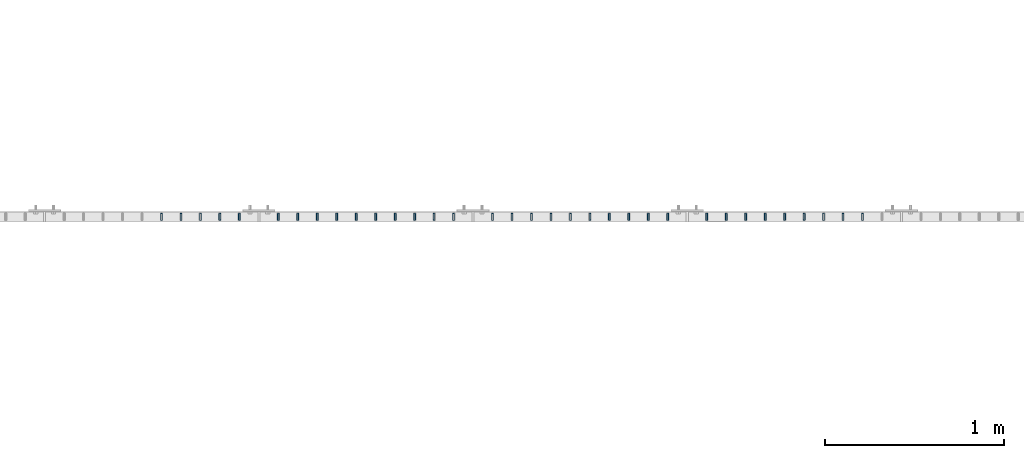
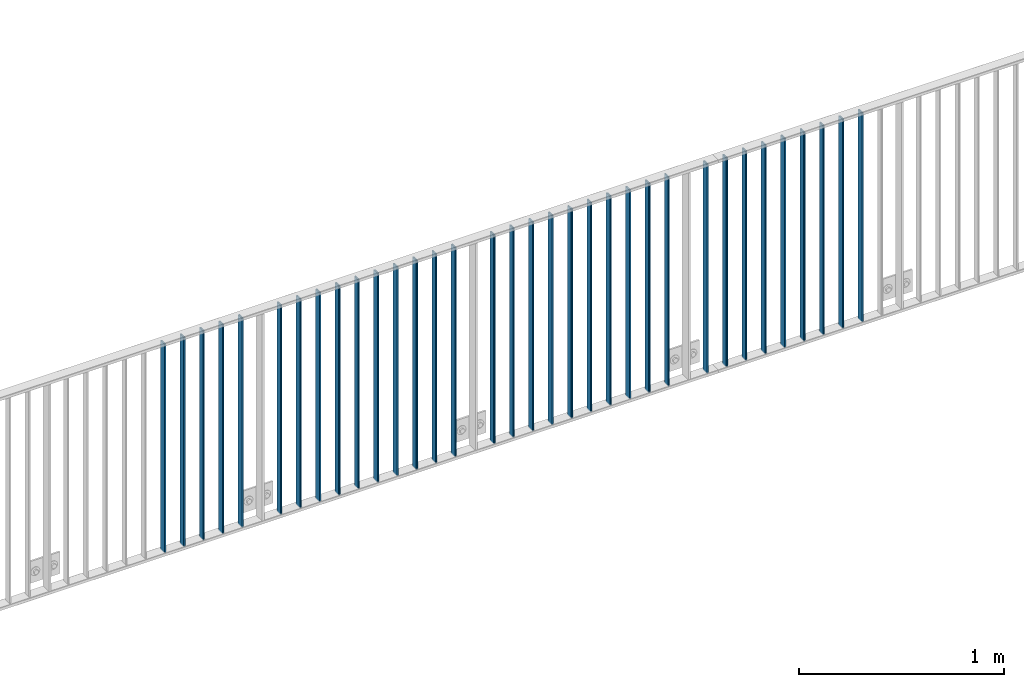
# One storey, part 3 of 156: 34 beams, 2 elements without a shape of their own.
"""IFC2X3 building model written with IfcOpenShell, lengths in millimetres."""

from ifc_helpers import new_model, si_unit, frame, origin_with_axes, origin_2d_with_axis, place, context, subcontext, project, spatial, hollow_rectangle, extrude, clip, halfspace, material, type_object, element, aggregate, save


model = new_model("IFC2X3")

# Units and contexts
model_context = context("Model", 3, precision=1e-05, world=origin_with_axes())
body_context = subcontext(model_context, "Body", "Model", "MODEL_VIEW")
ifc_project = project(units=[si_unit("LENGTHUNIT", "METRE", prefix="MILLI"), si_unit("AREAUNIT", "SQUARE_METRE"), si_unit("VOLUMEUNIT", "CUBIC_METRE"), si_unit("MASSUNIT", "GRAM", prefix="KILO"), si_unit("TIMEUNIT", "SECOND"), si_unit("PLANEANGLEUNIT", "RADIAN"), si_unit("SOLIDANGLEUNIT", "STERADIAN"), si_unit("THERMODYNAMICTEMPERATUREUNIT", "DEGREE_CELSIUS"), si_unit("LUMINOUSINTENSITYUNIT", "LUMEN")], contexts=[model_context])

# Site, building, storey
site_placement = place(None, origin_with_axes())
site = spatial("IfcSite", under=ifc_project, at=site_placement, CompositionType="ELEMENT")
building_placement = place(site_placement, origin_with_axes())
building = spatial("IfcBuilding", under=site, at=building_placement, Name="Undefined", CompositionType="ELEMENT")
storey_placement = place(building_placement, origin_with_axes())
storey = spatial("IfcBuildingStorey", under=building, at=storey_placement, Name="Undefined", CompositionType="ELEMENT", Elevation=0.0)

# Assembly, beams
assembly_1_placement = place(storey_placement, origin_with_axes())
assembly_1 = element("IfcElementAssembly", 1, at=assembly_1_placement, inside=storey, AssemblyPlace="NOTDEFINED", PredefinedType="RIGID_FRAME")
ifc_material = material(Name="STEEL/S235JR")
beam_type = type_object("IfcBeamType", Name="K40/10/1.5", PredefinedType="NOTDEFINED")
beam_1_placement = place(assembly_1_placement, frame((15181.809999999, 10879.9998088346, 3980.00000000003), z_axis=(0.0, 1.0, 0.0), x_axis=(0.0, 0.0, -1.0)))
beam_1 = element("IfcBeam", 2, at=beam_1_placement, type_object=beam_type, material=ifc_material, ObjectType="K40/10/1.5", context=body_context, shape_type="Clipping", body=[
    clip(clip(extrude(hollow_rectangle(XDim=10.0, YDim=40.0, WallThickness=1.5, InnerFilletRadius=1.5, OuterFilletRadius=3.0, at=origin_2d_with_axis()), frame((1237.00000000003, 0.0, 0.0), z_axis=(-1.0, 0.0, 0.0), x_axis=(0.0, -1.0, 0.0)), (0.0, 0.0, 1.0), 1244.0), halfspace(frame((1237.00000000003, 3.90376720472705, 47.0154897941684), z_axis=(1.0, 0.0, 0.0), x_axis=(0.0, -0.761952806119621, -0.647632551101653)), False)), halfspace(frame((-6.99999999997453, -3.24498419219526, 46.4665039507308), z_axis=(-1.0, 0.0, 0.0), x_axis=(0.0, 0.75441426312288, -0.656398598106944)), False)),
])
beam_2_placement = place(assembly_1_placement, frame((15072.719999999, 10879.9998088346, 3980.00000000003), z_axis=(0.0, 1.0, 0.0), x_axis=(0.0, 0.0, -1.0)))
beam_2 = element("IfcBeam", 3, at=beam_2_placement, type_object=beam_type, material=ifc_material, ObjectType="K40/10/1.5", context=body_context, shape_type="Clipping", body=[
    clip(clip(extrude(hollow_rectangle(XDim=10.0, YDim=40.0, WallThickness=1.5, InnerFilletRadius=1.5, OuterFilletRadius=3.0, at=origin_2d_with_axis()), frame((1237.00000000003, 0.0, 0.0), z_axis=(-1.0, 0.0, 0.0), x_axis=(0.0, -1.0, 0.0)), (0.0, 0.0, 1.0), 1244.0), halfspace(frame((1237.00000000003, 3.90376720472705, 47.0154897941684), z_axis=(1.0, 0.0, 0.0), x_axis=(0.0, -0.761952806119621, -0.647632551101653)), False)), halfspace(frame((-6.99999999997453, -3.24498419219526, 46.4665039507308), z_axis=(-1.0, 0.0, 0.0), x_axis=(0.0, 0.75441426312288, -0.656398598106944)), False)),
])
beam_3_placement = place(assembly_1_placement, frame((14963.629999999, 10879.9998088346, 3980.00000000003), z_axis=(0.0, 1.0, 0.0), x_axis=(0.0, 0.0, -1.0)))
beam_3 = element("IfcBeam", 4, at=beam_3_placement, type_object=beam_type, material=ifc_material, ObjectType="K40/10/1.5", context=body_context, shape_type="Clipping", body=[
    clip(clip(extrude(hollow_rectangle(XDim=10.0, YDim=40.0, WallThickness=1.5, InnerFilletRadius=1.5, OuterFilletRadius=3.0, at=origin_2d_with_axis()), frame((1237.00000000003, 0.0, 0.0), z_axis=(-1.0, 0.0, 0.0), x_axis=(0.0, -1.0, 0.0)), (0.0, 0.0, 1.0), 1244.0), halfspace(frame((1237.00000000003, 3.90376720472705, 47.0154897941684), z_axis=(1.0, 0.0, 0.0), x_axis=(0.0, -0.761952806119621, -0.647632551101653)), False)), halfspace(frame((-6.99999999997453, -3.24498419219526, 46.4665039507308), z_axis=(-1.0, 0.0, 0.0), x_axis=(0.0, 0.75441426312288, -0.656398598106944)), False)),
])
beam_4_placement = place(assembly_1_placement, frame((14854.539999999, 10879.9998088346, 3980.00000000003), z_axis=(0.0, 1.0, 0.0), x_axis=(0.0, 0.0, -1.0)))
beam_4 = element("IfcBeam", 5, at=beam_4_placement, type_object=beam_type, material=ifc_material, ObjectType="K40/10/1.5", context=body_context, shape_type="Clipping", body=[
    clip(clip(extrude(hollow_rectangle(XDim=10.0, YDim=40.0, WallThickness=1.5, InnerFilletRadius=1.5, OuterFilletRadius=3.0, at=origin_2d_with_axis()), frame((1237.00000000003, 0.0, 0.0), z_axis=(-1.0, 0.0, 0.0), x_axis=(0.0, -1.0, 0.0)), (0.0, 0.0, 1.0), 1244.0), halfspace(frame((1237.00000000003, 3.90376720472705, 47.0154897941684), z_axis=(1.0, 0.0, 0.0), x_axis=(0.0, -0.761952806119621, -0.647632551101653)), False)), halfspace(frame((-6.99999999997453, -3.24498419219526, 46.4665039507308), z_axis=(-1.0, 0.0, 0.0), x_axis=(0.0, 0.75441426312288, -0.656398598106944)), False)),
])
beam_5_placement = place(assembly_1_placement, frame((14745.449999999, 10879.9998088346, 3980.00000000003), z_axis=(0.0, 1.0, 0.0), x_axis=(0.0, 0.0, -1.0)))
beam_5 = element("IfcBeam", 6, at=beam_5_placement, type_object=beam_type, material=ifc_material, ObjectType="K40/10/1.5", context=body_context, shape_type="Clipping", body=[
    clip(clip(extrude(hollow_rectangle(XDim=10.0, YDim=40.0, WallThickness=1.5, InnerFilletRadius=1.5, OuterFilletRadius=3.0, at=origin_2d_with_axis()), frame((1237.00000000003, 0.0, 0.0), z_axis=(-1.0, 0.0, 0.0), x_axis=(0.0, -1.0, 0.0)), (0.0, 0.0, 1.0), 1244.0), halfspace(frame((1237.00000000003, 3.90376720472705, 47.0154897941684), z_axis=(1.0, 0.0, 0.0), x_axis=(0.0, -0.761952806119621, -0.647632551101653)), False)), halfspace(frame((-6.99999999997453, -3.24498419219526, 46.4665039507308), z_axis=(-1.0, 0.0, 0.0), x_axis=(0.0, 0.75441426312288, -0.656398598106944)), False)),
])
beam_6_placement = place(assembly_1_placement, frame((14636.359999999, 10879.9998088346, 3980.00000000003), z_axis=(0.0, 1.0, 0.0), x_axis=(0.0, 0.0, -1.0)))
beam_6 = element("IfcBeam", 7, at=beam_6_placement, type_object=beam_type, material=ifc_material, ObjectType="K40/10/1.5", context=body_context, shape_type="Clipping", body=[
    clip(clip(extrude(hollow_rectangle(XDim=10.0, YDim=40.0, WallThickness=1.5, InnerFilletRadius=1.5, OuterFilletRadius=3.0, at=origin_2d_with_axis()), frame((1237.00000000003, 0.0, 0.0), z_axis=(-1.0, 0.0, 0.0), x_axis=(0.0, -1.0, 0.0)), (0.0, 0.0, 1.0), 1244.0), halfspace(frame((1237.00000000003, 3.90376720472705, 47.0154897941684), z_axis=(1.0, 0.0, 0.0), x_axis=(0.0, -0.761952806119621, -0.647632551101653)), False)), halfspace(frame((-6.99999999997453, -3.24498419219526, 46.4665039507308), z_axis=(-1.0, 0.0, 0.0), x_axis=(0.0, 0.75441426312288, -0.656398598106944)), False)),
])
beam_7_placement = place(assembly_1_placement, frame((14527.269999999, 10879.9998088346, 3980.00000000003), z_axis=(0.0, 1.0, 0.0), x_axis=(0.0, 0.0, -1.0)))
beam_7 = element("IfcBeam", 8, at=beam_7_placement, type_object=beam_type, material=ifc_material, ObjectType="K40/10/1.5", context=body_context, shape_type="Clipping", body=[
    clip(clip(extrude(hollow_rectangle(XDim=10.0, YDim=40.0, WallThickness=1.5, InnerFilletRadius=1.5, OuterFilletRadius=3.0, at=origin_2d_with_axis()), frame((1237.00000000003, 0.0, 0.0), z_axis=(-1.0, 0.0, 0.0), x_axis=(0.0, -1.0, 0.0)), (0.0, 0.0, 1.0), 1244.0), halfspace(frame((1237.00000000003, 3.90376720472705, 47.0154897941684), z_axis=(1.0, 0.0, 0.0), x_axis=(0.0, -0.761952806119621, -0.647632551101653)), False)), halfspace(frame((-6.99999999997453, -3.24498419219526, 46.4665039507308), z_axis=(-1.0, 0.0, 0.0), x_axis=(0.0, 0.75441426312288, -0.656398598106944)), False)),
])
beam_8_placement = place(assembly_1_placement, frame((14418.179999999, 10879.9998088346, 3980.00000000003), z_axis=(0.0, 1.0, 0.0), x_axis=(0.0, 0.0, -1.0)))
beam_8 = element("IfcBeam", 9, at=beam_8_placement, type_object=beam_type, material=ifc_material, ObjectType="K40/10/1.5", context=body_context, shape_type="Clipping", body=[
    clip(clip(extrude(hollow_rectangle(XDim=10.0, YDim=40.0, WallThickness=1.5, InnerFilletRadius=1.5, OuterFilletRadius=3.0, at=origin_2d_with_axis()), frame((1237.00000000003, 0.0, 0.0), z_axis=(-1.0, 0.0, 0.0), x_axis=(0.0, -1.0, 0.0)), (0.0, 0.0, 1.0), 1244.0), halfspace(frame((1237.00000000003, -1.3499595544381, 42.6373841643144), z_axis=(1.0, 0.0, 0.0), x_axis=(0.0, -0.69932069855901, -0.714808058549243)), False)), halfspace(frame((-6.99999999997453, -3.24498419219526, 46.4665039507308), z_axis=(-1.0, 0.0, 0.0), x_axis=(0.0, 0.75441426312288, -0.656398598106944)), False)),
])
aggregate(assembly_1, [beam_1, beam_2, beam_3, beam_4, beam_5, beam_6, beam_7, beam_8])

assembly_2_placement = place(storey_placement, origin_with_axes())
assembly_2 = element("IfcElementAssembly", 10, at=assembly_2_placement, inside=storey, AssemblyPlace="NOTDEFINED", PredefinedType="RIGID_FRAME")
beam_9_placement = place(assembly_2_placement, frame((14309.089999999, 10879.9998088346, 3980.00000000003), z_axis=(0.0, 1.0, 0.0), x_axis=(0.0, 0.0, -1.0)))
beam_9 = element("IfcBeam", 11, at=beam_9_placement, type_object=beam_type, material=ifc_material, ObjectType="K40/10/1.5", context=body_context, shape_type="Clipping", body=[
    clip(clip(extrude(hollow_rectangle(XDim=10.0, YDim=40.0, WallThickness=1.5, InnerFilletRadius=1.5, OuterFilletRadius=3.0, at=origin_2d_with_axis()), frame((1237.00000000003, 0.0, 0.0), z_axis=(-1.0, 0.0, 0.0), x_axis=(0.0, -1.0, 0.0)), (0.0, 0.0, 1.0), 1244.0), halfspace(frame((1237.00000000003, 0.531585963377438, 44.2053387614833), z_axis=(1.0, 0.0, 0.0), x_axis=(0.0, -0.72237744111132, -0.691498975106588)), False)), halfspace(frame((-6.99999999997453, 1.34995955444174, 42.6373841643144), z_axis=(-1.0, 0.0, 0.0), x_axis=(0.0, 0.699320698559008, -0.714808058549245)), False)),
])
beam_10_placement = place(assembly_2_placement, frame((14090.899999999, 10879.9998088346, 3980.00000000003), z_axis=(0.0, 1.0, 0.0), x_axis=(0.0, 0.0, -1.0)))
beam_10 = element("IfcBeam", 12, at=beam_10_placement, type_object=beam_type, material=ifc_material, ObjectType="K40/10/1.5", context=body_context, shape_type="Clipping", body=[
    clip(clip(extrude(hollow_rectangle(XDim=10.0, YDim=40.0, WallThickness=1.5, InnerFilletRadius=1.5, OuterFilletRadius=3.0, at=origin_2d_with_axis()), frame((1237.00000000003, 0.0, 0.0), z_axis=(-1.0, 0.0, 0.0), x_axis=(0.0, -1.0, 0.0)), (0.0, 0.0, 1.0), 1244.0), halfspace(frame((1237.00000000003, 1.80362172154128, 45.2653685592795), z_axis=(1.0, 0.0, 0.0), x_axis=(0.0, -0.737586551668085, -0.675252603696115)), False)), halfspace(frame((-6.99999999997453, -0.5315859633738, 44.2053387614833), z_axis=(-1.0, 0.0, 0.0), x_axis=(0.0, 0.722377441111346, -0.691498975106561)), False)),
])
beam_11_placement = place(assembly_2_placement, frame((13981.809999999, 10879.9998088346, 3980.00000000003), z_axis=(0.0, 1.0, 0.0), x_axis=(0.0, 0.0, -1.0)))
beam_11 = element("IfcBeam", 13, at=beam_11_placement, type_object=beam_type, material=ifc_material, ObjectType="K40/10/1.5", context=body_context, shape_type="Clipping", body=[
    clip(clip(extrude(hollow_rectangle(XDim=10.0, YDim=40.0, WallThickness=1.5, InnerFilletRadius=1.5, OuterFilletRadius=3.0, at=origin_2d_with_axis()), frame((1237.00000000003, 0.0, 0.0), z_axis=(-1.0, 0.0, 0.0), x_axis=(0.0, -1.0, 0.0)), (0.0, 0.0, 1.0), 1244.0), halfspace(frame((1237.00000000003, 1.80362172154128, 45.2653685592795), z_axis=(1.0, 0.0, 0.0), x_axis=(0.0, -0.737586551668085, -0.675252603696115)), False)), halfspace(frame((-6.99999999997453, -0.5315859633738, 44.2053387614833), z_axis=(-1.0, 0.0, 0.0), x_axis=(0.0, 0.722377441111346, -0.691498975106561)), False)),
])
beam_12_placement = place(assembly_2_placement, frame((13872.719999999, 10879.9998088346, 3980.00000000003), z_axis=(0.0, 1.0, 0.0), x_axis=(0.0, 0.0, -1.0)))
beam_12 = element("IfcBeam", 14, at=beam_12_placement, type_object=beam_type, material=ifc_material, ObjectType="K40/10/1.5", context=body_context, shape_type="Clipping", body=[
    clip(clip(extrude(hollow_rectangle(XDim=10.0, YDim=40.0, WallThickness=1.5, InnerFilletRadius=1.5, OuterFilletRadius=3.0, at=origin_2d_with_axis()), frame((1237.00000000003, 0.0, 0.0), z_axis=(-1.0, 0.0, 0.0), x_axis=(0.0, -1.0, 0.0)), (0.0, 0.0, 1.0), 1244.0), halfspace(frame((1237.00000000003, 1.80362172154128, 45.2653685592795), z_axis=(1.0, 0.0, 0.0), x_axis=(0.0, -0.737586551668085, -0.675252603696115)), False)), halfspace(frame((-6.99999999997453, -0.5315859633738, 44.2053387614833), z_axis=(-1.0, 0.0, 0.0), x_axis=(0.0, 0.722377441111346, -0.691498975106561)), False)),
])
beam_13_placement = place(assembly_2_placement, frame((13763.629999999, 10879.9998088346, 3980.00000000003), z_axis=(0.0, 1.0, 0.0), x_axis=(0.0, 0.0, -1.0)))
beam_13 = element("IfcBeam", 15, at=beam_13_placement, type_object=beam_type, material=ifc_material, ObjectType="K40/10/1.5", context=body_context, shape_type="Clipping", body=[
    clip(clip(extrude(hollow_rectangle(XDim=10.0, YDim=40.0, WallThickness=1.5, InnerFilletRadius=1.5, OuterFilletRadius=3.0, at=origin_2d_with_axis()), frame((1237.00000000003, 0.0, 0.0), z_axis=(-1.0, 0.0, 0.0), x_axis=(0.0, -1.0, 0.0)), (0.0, 0.0, 1.0), 1244.0), halfspace(frame((1237.00000000003, 1.80362172154128, 45.2653685592795), z_axis=(1.0, 0.0, 0.0), x_axis=(0.0, -0.737586551668085, -0.675252603696115)), False)), halfspace(frame((-6.99999999997453, -0.5315859633738, 44.2053387614833), z_axis=(-1.0, 0.0, 0.0), x_axis=(0.0, 0.722377441111346, -0.691498975106561)), False)),
])
beam_14_placement = place(assembly_2_placement, frame((13654.539999999, 10879.9998088346, 3980.00000000003), z_axis=(0.0, 1.0, 0.0), x_axis=(0.0, 0.0, -1.0)))
beam_14 = element("IfcBeam", 16, at=beam_14_placement, type_object=beam_type, material=ifc_material, ObjectType="K40/10/1.5", context=body_context, shape_type="Clipping", body=[
    clip(clip(extrude(hollow_rectangle(XDim=10.0, YDim=40.0, WallThickness=1.5, InnerFilletRadius=1.5, OuterFilletRadius=3.0, at=origin_2d_with_axis()), frame((1237.00000000003, 0.0, 0.0), z_axis=(-1.0, 0.0, 0.0), x_axis=(0.0, -1.0, 0.0)), (0.0, 0.0, 1.0), 1244.0), halfspace(frame((1237.00000000003, 1.80362172154128, 45.2653685592795), z_axis=(1.0, 0.0, 0.0), x_axis=(0.0, -0.737586551668085, -0.675252603696115)), False)), halfspace(frame((-6.99999999997453, -0.5315859633738, 44.2053387614833), z_axis=(-1.0, 0.0, 0.0), x_axis=(0.0, 0.722377441111346, -0.691498975106561)), False)),
])
beam_15_placement = place(assembly_2_placement, frame((13545.449999999, 10879.9998088346, 3980.00000000003), z_axis=(0.0, 1.0, 0.0), x_axis=(0.0, 0.0, -1.0)))
beam_15 = element("IfcBeam", 17, at=beam_15_placement, type_object=beam_type, material=ifc_material, ObjectType="K40/10/1.5", context=body_context, shape_type="Clipping", body=[
    clip(clip(extrude(hollow_rectangle(XDim=10.0, YDim=40.0, WallThickness=1.5, InnerFilletRadius=1.5, OuterFilletRadius=3.0, at=origin_2d_with_axis()), frame((1237.00000000003, 0.0, 0.0), z_axis=(-1.0, 0.0, 0.0), x_axis=(0.0, -1.0, 0.0)), (0.0, 0.0, 1.0), 1244.0), halfspace(frame((1237.00000000003, 1.80362172154128, 45.2653685592795), z_axis=(1.0, 0.0, 0.0), x_axis=(0.0, -0.737586551668085, -0.675252603696115)), False)), halfspace(frame((-6.99999999997453, -0.5315859633738, 44.2053387614833), z_axis=(-1.0, 0.0, 0.0), x_axis=(0.0, 0.722377441111346, -0.691498975106561)), False)),
])
beam_16_placement = place(assembly_2_placement, frame((13436.359999999, 10879.9998088346, 3980.00000000003), z_axis=(0.0, 1.0, 0.0), x_axis=(0.0, 0.0, -1.0)))
beam_16 = element("IfcBeam", 18, at=beam_16_placement, type_object=beam_type, material=ifc_material, ObjectType="K40/10/1.5", context=body_context, shape_type="Clipping", body=[
    clip(clip(extrude(hollow_rectangle(XDim=10.0, YDim=40.0, WallThickness=1.5, InnerFilletRadius=1.5, OuterFilletRadius=3.0, at=origin_2d_with_axis()), frame((1237.00000000003, 0.0, 0.0), z_axis=(-1.0, 0.0, 0.0), x_axis=(0.0, -1.0, 0.0)), (0.0, 0.0, 1.0), 1244.0), halfspace(frame((1237.00000000003, 1.80362172154128, 45.2653685592795), z_axis=(1.0, 0.0, 0.0), x_axis=(0.0, -0.737586551668085, -0.675252603696115)), False)), halfspace(frame((-6.99999999997453, -0.5315859633738, 44.2053387614833), z_axis=(-1.0, 0.0, 0.0), x_axis=(0.0, 0.722377441111346, -0.691498975106561)), False)),
])
beam_17_placement = place(assembly_2_placement, frame((13327.269999999, 10879.9998088346, 3980.00000000003), z_axis=(0.0, 1.0, 0.0), x_axis=(0.0, 0.0, -1.0)))
beam_17 = element("IfcBeam", 19, at=beam_17_placement, type_object=beam_type, material=ifc_material, ObjectType="K40/10/1.5", context=body_context, shape_type="Clipping", body=[
    clip(clip(extrude(hollow_rectangle(XDim=10.0, YDim=40.0, WallThickness=1.5, InnerFilletRadius=1.5, OuterFilletRadius=3.0, at=origin_2d_with_axis()), frame((1237.00000000003, 0.0, 0.0), z_axis=(-1.0, 0.0, 0.0), x_axis=(0.0, -1.0, 0.0)), (0.0, 0.0, 1.0), 1244.0), halfspace(frame((1237.00000000003, 1.80362172154128, 45.2653685592795), z_axis=(1.0, 0.0, 0.0), x_axis=(0.0, -0.737586551668085, -0.675252603696115)), False)), halfspace(frame((-6.99999999997453, -0.5315859633738, 44.2053387614833), z_axis=(-1.0, 0.0, 0.0), x_axis=(0.0, 0.722377441111346, -0.691498975106561)), False)),
])
beam_18_placement = place(assembly_2_placement, frame((13218.179999999, 10879.9998088346, 3980.00000000003), z_axis=(0.0, 1.0, 0.0), x_axis=(0.0, 0.0, -1.0)))
beam_18 = element("IfcBeam", 20, at=beam_18_placement, type_object=beam_type, material=ifc_material, ObjectType="K40/10/1.5", context=body_context, shape_type="Clipping", body=[
    clip(clip(extrude(hollow_rectangle(XDim=10.0, YDim=40.0, WallThickness=1.5, InnerFilletRadius=1.5, OuterFilletRadius=3.0, at=origin_2d_with_axis()), frame((1237.00000000003, 0.0, 0.0), z_axis=(-1.0, 0.0, 0.0), x_axis=(0.0, -1.0, 0.0)), (0.0, 0.0, 1.0), 1244.0), halfspace(frame((1237.00000000003, 1.80362172154128, 45.2653685592795), z_axis=(1.0, 0.0, 0.0), x_axis=(0.0, -0.737586551668085, -0.675252603696115)), False)), halfspace(frame((-6.99999999997453, -0.5315859633738, 44.2053387614833), z_axis=(-1.0, 0.0, 0.0), x_axis=(0.0, 0.722377441111346, -0.691498975106561)), False)),
])
beam_19_placement = place(assembly_2_placement, frame((13109.089999999, 10879.9998088346, 3980.00000000003), z_axis=(0.0, 1.0, 0.0), x_axis=(0.0, 0.0, -1.0)))
beam_19 = element("IfcBeam", 21, at=beam_19_placement, type_object=beam_type, material=ifc_material, ObjectType="K40/10/1.5", context=body_context, shape_type="Clipping", body=[
    clip(clip(extrude(hollow_rectangle(XDim=10.0, YDim=40.0, WallThickness=1.5, InnerFilletRadius=1.5, OuterFilletRadius=3.0, at=origin_2d_with_axis()), frame((1237.00000000003, 0.0, 0.0), z_axis=(-1.0, 0.0, 0.0), x_axis=(0.0, -1.0, 0.0)), (0.0, 0.0, 1.0), 1244.0), halfspace(frame((1237.00000000003, 0.531585963377438, 44.2053387614833), z_axis=(1.0, 0.0, 0.0), x_axis=(0.0, -0.72237744111132, -0.691498975106588)), False)), halfspace(frame((-6.99999999997453, 1.34995955444174, 42.6373841643144), z_axis=(-1.0, 0.0, 0.0), x_axis=(0.0, 0.699320698559008, -0.714808058549245)), False)),
])
beam_20_placement = place(assembly_2_placement, frame((12890.899999999, 10879.9998088346, 3980.00000000003), z_axis=(0.0, 1.0, 0.0), x_axis=(0.0, 0.0, -1.0)))
beam_20 = element("IfcBeam", 22, at=beam_20_placement, type_object=beam_type, material=ifc_material, ObjectType="K40/10/1.5", context=body_context, shape_type="Clipping", body=[
    clip(clip(extrude(hollow_rectangle(XDim=10.0, YDim=40.0, WallThickness=1.5, InnerFilletRadius=1.5, OuterFilletRadius=3.0, at=origin_2d_with_axis()), frame((1237.00000000003, 0.0, 0.0), z_axis=(-1.0, 0.0, 0.0), x_axis=(0.0, -1.0, 0.0)), (0.0, 0.0, 1.0), 1244.0), halfspace(frame((1237.00000000003, 1.80362172154128, 45.2653685592795), z_axis=(1.0, 0.0, 0.0), x_axis=(0.0, -0.737586551668085, -0.675252603696115)), False)), halfspace(frame((-6.99999999997453, -0.5315859633738, 44.2053387614833), z_axis=(-1.0, 0.0, 0.0), x_axis=(0.0, 0.722377441111346, -0.691498975106561)), False)),
])
beam_21_placement = place(assembly_2_placement, frame((12781.809999999, 10879.9998088346, 3980.00000000003), z_axis=(0.0, 1.0, 0.0), x_axis=(0.0, 0.0, -1.0)))
beam_21 = element("IfcBeam", 23, at=beam_21_placement, type_object=beam_type, material=ifc_material, ObjectType="K40/10/1.5", context=body_context, shape_type="Clipping", body=[
    clip(clip(extrude(hollow_rectangle(XDim=10.0, YDim=40.0, WallThickness=1.5, InnerFilletRadius=1.5, OuterFilletRadius=3.0, at=origin_2d_with_axis()), frame((1237.00000000003, 0.0, 0.0), z_axis=(-1.0, 0.0, 0.0), x_axis=(0.0, -1.0, 0.0)), (0.0, 0.0, 1.0), 1244.0), halfspace(frame((1237.00000000003, 1.80362172154128, 45.2653685592795), z_axis=(1.0, 0.0, 0.0), x_axis=(0.0, -0.737586551668085, -0.675252603696115)), False)), halfspace(frame((-6.99999999997453, -0.5315859633738, 44.2053387614833), z_axis=(-1.0, 0.0, 0.0), x_axis=(0.0, 0.722377441111346, -0.691498975106561)), False)),
])
beam_22_placement = place(assembly_2_placement, frame((12672.719999999, 10879.9998088346, 3980.00000000003), z_axis=(0.0, 1.0, 0.0), x_axis=(0.0, 0.0, -1.0)))
beam_22 = element("IfcBeam", 24, at=beam_22_placement, type_object=beam_type, material=ifc_material, ObjectType="K40/10/1.5", context=body_context, shape_type="Clipping", body=[
    clip(clip(extrude(hollow_rectangle(XDim=10.0, YDim=40.0, WallThickness=1.5, InnerFilletRadius=1.5, OuterFilletRadius=3.0, at=origin_2d_with_axis()), frame((1237.00000000003, 0.0, 0.0), z_axis=(-1.0, 0.0, 0.0), x_axis=(0.0, -1.0, 0.0)), (0.0, 0.0, 1.0), 1244.0), halfspace(frame((1237.00000000003, 1.80362172154128, 45.2653685592795), z_axis=(1.0, 0.0, 0.0), x_axis=(0.0, -0.737586551668085, -0.675252603696115)), False)), halfspace(frame((-6.99999999997453, -0.5315859633738, 44.2053387614833), z_axis=(-1.0, 0.0, 0.0), x_axis=(0.0, 0.722377441111346, -0.691498975106561)), False)),
])
beam_23_placement = place(assembly_2_placement, frame((12563.629999999, 10879.9998088346, 3980.00000000003), z_axis=(0.0, 1.0, 0.0), x_axis=(0.0, 0.0, -1.0)))
beam_23 = element("IfcBeam", 25, at=beam_23_placement, type_object=beam_type, material=ifc_material, ObjectType="K40/10/1.5", context=body_context, shape_type="Clipping", body=[
    clip(clip(extrude(hollow_rectangle(XDim=10.0, YDim=40.0, WallThickness=1.5, InnerFilletRadius=1.5, OuterFilletRadius=3.0, at=origin_2d_with_axis()), frame((1237.00000000003, 0.0, 0.0), z_axis=(-1.0, 0.0, 0.0), x_axis=(0.0, -1.0, 0.0)), (0.0, 0.0, 1.0), 1244.0), halfspace(frame((1237.00000000003, 1.80362172154128, 45.2653685592795), z_axis=(1.0, 0.0, 0.0), x_axis=(0.0, -0.737586551668085, -0.675252603696115)), False)), halfspace(frame((-6.99999999997453, -0.5315859633738, 44.2053387614833), z_axis=(-1.0, 0.0, 0.0), x_axis=(0.0, 0.722377441111346, -0.691498975106561)), False)),
])
beam_24_placement = place(assembly_2_placement, frame((12454.539999999, 10879.9998088346, 3980.00000000003), z_axis=(0.0, 1.0, 0.0), x_axis=(0.0, 0.0, -1.0)))
beam_24 = element("IfcBeam", 26, at=beam_24_placement, type_object=beam_type, material=ifc_material, ObjectType="K40/10/1.5", context=body_context, shape_type="Clipping", body=[
    clip(clip(extrude(hollow_rectangle(XDim=10.0, YDim=40.0, WallThickness=1.5, InnerFilletRadius=1.5, OuterFilletRadius=3.0, at=origin_2d_with_axis()), frame((1237.00000000003, 0.0, 0.0), z_axis=(-1.0, 0.0, 0.0), x_axis=(0.0, -1.0, 0.0)), (0.0, 0.0, 1.0), 1244.0), halfspace(frame((1237.00000000003, 1.80362172154128, 45.2653685592795), z_axis=(1.0, 0.0, 0.0), x_axis=(0.0, -0.737586551668085, -0.675252603696115)), False)), halfspace(frame((-6.99999999997453, -0.5315859633738, 44.2053387614833), z_axis=(-1.0, 0.0, 0.0), x_axis=(0.0, 0.722377441111346, -0.691498975106561)), False)),
])
beam_25_placement = place(assembly_2_placement, frame((12345.449999999, 10879.9998088346, 3980.00000000003), z_axis=(0.0, 1.0, 0.0), x_axis=(0.0, 0.0, -1.0)))
beam_25 = element("IfcBeam", 27, at=beam_25_placement, type_object=beam_type, material=ifc_material, ObjectType="K40/10/1.5", context=body_context, shape_type="Clipping", body=[
    clip(clip(extrude(hollow_rectangle(XDim=10.0, YDim=40.0, WallThickness=1.5, InnerFilletRadius=1.5, OuterFilletRadius=3.0, at=origin_2d_with_axis()), frame((1237.00000000003, 0.0, 0.0), z_axis=(-1.0, 0.0, 0.0), x_axis=(0.0, -1.0, 0.0)), (0.0, 0.0, 1.0), 1244.0), halfspace(frame((1237.00000000003, 1.80362172154128, 45.2653685592795), z_axis=(1.0, 0.0, 0.0), x_axis=(0.0, -0.737586551668085, -0.675252603696115)), False)), halfspace(frame((-6.99999999997453, -0.5315859633738, 44.2053387614833), z_axis=(-1.0, 0.0, 0.0), x_axis=(0.0, 0.722377441111346, -0.691498975106561)), False)),
])
beam_26_placement = place(assembly_2_placement, frame((12236.359999999, 10879.9998088346, 3980.00000000003), z_axis=(0.0, 1.0, 0.0), x_axis=(0.0, 0.0, -1.0)))
beam_26 = element("IfcBeam", 28, at=beam_26_placement, type_object=beam_type, material=ifc_material, ObjectType="K40/10/1.5", context=body_context, shape_type="Clipping", body=[
    clip(clip(extrude(hollow_rectangle(XDim=10.0, YDim=40.0, WallThickness=1.5, InnerFilletRadius=1.5, OuterFilletRadius=3.0, at=origin_2d_with_axis()), frame((1237.00000000003, 0.0, 0.0), z_axis=(-1.0, 0.0, 0.0), x_axis=(0.0, -1.0, 0.0)), (0.0, 0.0, 1.0), 1244.0), halfspace(frame((1237.00000000003, 1.80362172154128, 45.2653685592795), z_axis=(1.0, 0.0, 0.0), x_axis=(0.0, -0.737586551668085, -0.675252603696115)), False)), halfspace(frame((-6.99999999997453, -0.5315859633738, 44.2053387614833), z_axis=(-1.0, 0.0, 0.0), x_axis=(0.0, 0.722377441111346, -0.691498975106561)), False)),
])
beam_27_placement = place(assembly_2_placement, frame((12127.269999999, 10879.9998088346, 3980.00000000003), z_axis=(0.0, 1.0, 0.0), x_axis=(0.0, 0.0, -1.0)))
beam_27 = element("IfcBeam", 29, at=beam_27_placement, type_object=beam_type, material=ifc_material, ObjectType="K40/10/1.5", context=body_context, shape_type="Clipping", body=[
    clip(clip(extrude(hollow_rectangle(XDim=10.0, YDim=40.0, WallThickness=1.5, InnerFilletRadius=1.5, OuterFilletRadius=3.0, at=origin_2d_with_axis()), frame((1237.00000000003, 0.0, 0.0), z_axis=(-1.0, 0.0, 0.0), x_axis=(0.0, -1.0, 0.0)), (0.0, 0.0, 1.0), 1244.0), halfspace(frame((1237.00000000003, 1.80362172154128, 45.2653685592795), z_axis=(1.0, 0.0, 0.0), x_axis=(0.0, -0.737586551668085, -0.675252603696115)), False)), halfspace(frame((-6.99999999997453, -0.5315859633738, 44.2053387614833), z_axis=(-1.0, 0.0, 0.0), x_axis=(0.0, 0.722377441111346, -0.691498975106561)), False)),
])
beam_28_placement = place(assembly_2_placement, frame((12018.179999999, 10879.9998088346, 3980.00000000003), z_axis=(0.0, 1.0, 0.0), x_axis=(0.0, 0.0, -1.0)))
beam_28 = element("IfcBeam", 30, at=beam_28_placement, type_object=beam_type, material=ifc_material, ObjectType="K40/10/1.5", context=body_context, shape_type="Clipping", body=[
    clip(clip(extrude(hollow_rectangle(XDim=10.0, YDim=40.0, WallThickness=1.5, InnerFilletRadius=1.5, OuterFilletRadius=3.0, at=origin_2d_with_axis()), frame((1237.00000000003, 0.0, 0.0), z_axis=(-1.0, 0.0, 0.0), x_axis=(0.0, -1.0, 0.0)), (0.0, 0.0, 1.0), 1244.0), halfspace(frame((1237.00000000003, 1.80362172154128, 45.2653685592795), z_axis=(1.0, 0.0, 0.0), x_axis=(0.0, -0.737586551668085, -0.675252603696115)), False)), halfspace(frame((-6.99999999997453, -0.5315859633738, 44.2053387614833), z_axis=(-1.0, 0.0, 0.0), x_axis=(0.0, 0.722377441111346, -0.691498975106561)), False)),
])
beam_29_placement = place(assembly_2_placement, frame((11909.089999999, 10879.9998088346, 3980.00000000003), z_axis=(0.0, 1.0, 0.0), x_axis=(0.0, 0.0, -1.0)))
beam_29 = element("IfcBeam", 31, at=beam_29_placement, type_object=beam_type, material=ifc_material, ObjectType="K40/10/1.5", context=body_context, shape_type="Clipping", body=[
    clip(clip(extrude(hollow_rectangle(XDim=10.0, YDim=40.0, WallThickness=1.5, InnerFilletRadius=1.5, OuterFilletRadius=3.0, at=origin_2d_with_axis()), frame((1237.00000000003, 0.0, 0.0), z_axis=(-1.0, 0.0, 0.0), x_axis=(0.0, -1.0, 0.0)), (0.0, 0.0, 1.0), 1244.0), halfspace(frame((1237.00000000003, 0.531585963377438, 44.2053387614833), z_axis=(1.0, 0.0, 0.0), x_axis=(0.0, -0.72237744111132, -0.691498975106588)), False)), halfspace(frame((-6.99999999997453, 1.34995955444174, 42.6373841643144), z_axis=(-1.0, 0.0, 0.0), x_axis=(0.0, 0.699320698559008, -0.714808058549245)), False)),
])
beam_30_placement = place(assembly_2_placement, frame((11690.899999999, 10879.9998088346, 3980.00000000003), z_axis=(0.0, 1.0, 0.0), x_axis=(0.0, 0.0, -1.0)))
beam_30 = element("IfcBeam", 32, at=beam_30_placement, type_object=beam_type, material=ifc_material, ObjectType="K40/10/1.5", context=body_context, shape_type="Clipping", body=[
    clip(clip(extrude(hollow_rectangle(XDim=10.0, YDim=40.0, WallThickness=1.5, InnerFilletRadius=1.5, OuterFilletRadius=3.0, at=origin_2d_with_axis()), frame((1237.00000000003, 0.0, 0.0), z_axis=(-1.0, 0.0, 0.0), x_axis=(0.0, -1.0, 0.0)), (0.0, 0.0, 1.0), 1244.0), halfspace(frame((1237.00000000003, 0.531585963377438, 44.2053387614833), z_axis=(1.0, 0.0, 0.0), x_axis=(0.0, -0.72237744111132, -0.691498975106588)), False)), halfspace(frame((-6.99999999997453, 1.34995955444174, 42.6373841643144), z_axis=(-1.0, 0.0, 0.0), x_axis=(0.0, 0.699320698559008, -0.714808058549245)), False)),
])
beam_31_placement = place(assembly_2_placement, frame((11581.809999999, 10879.9998088346, 3980.00000000003), z_axis=(0.0, 1.0, 0.0), x_axis=(0.0, 0.0, -1.0)))
beam_31 = element("IfcBeam", 33, at=beam_31_placement, type_object=beam_type, material=ifc_material, ObjectType="K40/10/1.5", context=body_context, shape_type="Clipping", body=[
    clip(clip(extrude(hollow_rectangle(XDim=10.0, YDim=40.0, WallThickness=1.5, InnerFilletRadius=1.5, OuterFilletRadius=3.0, at=origin_2d_with_axis()), frame((1237.00000000003, 0.0, 0.0), z_axis=(-1.0, 0.0, 0.0), x_axis=(0.0, -1.0, 0.0)), (0.0, 0.0, 1.0), 1244.0), halfspace(frame((1237.00000000003, 0.531585963377438, 44.2053387614833), z_axis=(1.0, 0.0, 0.0), x_axis=(0.0, -0.72237744111132, -0.691498975106588)), False)), halfspace(frame((-6.99999999997453, 1.34995955444174, 42.6373841643144), z_axis=(-1.0, 0.0, 0.0), x_axis=(0.0, 0.699320698559008, -0.714808058549245)), False)),
])
beam_32_placement = place(assembly_2_placement, frame((11472.719999999, 10879.9998088346, 3980.00000000003), z_axis=(0.0, 1.0, 0.0), x_axis=(0.0, 0.0, -1.0)))
beam_32 = element("IfcBeam", 34, at=beam_32_placement, type_object=beam_type, material=ifc_material, ObjectType="K40/10/1.5", context=body_context, shape_type="Clipping", body=[
    clip(clip(extrude(hollow_rectangle(XDim=10.0, YDim=40.0, WallThickness=1.5, InnerFilletRadius=1.5, OuterFilletRadius=3.0, at=origin_2d_with_axis()), frame((1237.00000000003, 0.0, 0.0), z_axis=(-1.0, 0.0, 0.0), x_axis=(0.0, -1.0, 0.0)), (0.0, 0.0, 1.0), 1244.0), halfspace(frame((1237.00000000003, 0.531585963377438, 44.2053387614833), z_axis=(1.0, 0.0, 0.0), x_axis=(0.0, -0.72237744111132, -0.691498975106588)), False)), halfspace(frame((-6.99999999997453, 1.34995955444174, 42.6373841643144), z_axis=(-1.0, 0.0, 0.0), x_axis=(0.0, 0.699320698559008, -0.714808058549245)), False)),
])
beam_33_placement = place(assembly_2_placement, frame((11363.629999999, 10879.9998088346, 3980.00000000003), z_axis=(0.0, 1.0, 0.0), x_axis=(0.0, 0.0, -1.0)))
beam_33 = element("IfcBeam", 35, at=beam_33_placement, type_object=beam_type, material=ifc_material, ObjectType="K40/10/1.5", context=body_context, shape_type="Clipping", body=[
    clip(clip(extrude(hollow_rectangle(XDim=10.0, YDim=40.0, WallThickness=1.5, InnerFilletRadius=1.5, OuterFilletRadius=3.0, at=origin_2d_with_axis()), frame((1237.00000000003, 0.0, 0.0), z_axis=(-1.0, 0.0, 0.0), x_axis=(0.0, -1.0, 0.0)), (0.0, 0.0, 1.0), 1244.0), halfspace(frame((1237.00000000003, 0.531585963377438, 44.2053387614833), z_axis=(1.0, 0.0, 0.0), x_axis=(0.0, -0.72237744111132, -0.691498975106588)), False)), halfspace(frame((-6.99999999997453, 1.34995955444174, 42.6373841643144), z_axis=(-1.0, 0.0, 0.0), x_axis=(0.0, 0.699320698559008, -0.714808058549245)), False)),
])
beam_34_placement = place(assembly_2_placement, frame((11254.539999999, 10879.9998088346, 3980.00000000003), z_axis=(0.0, 1.0, 0.0), x_axis=(0.0, 0.0, -1.0)))
beam_34 = element("IfcBeam", 36, at=beam_34_placement, type_object=beam_type, material=ifc_material, ObjectType="K40/10/1.5", context=body_context, shape_type="Clipping", body=[
    clip(clip(extrude(hollow_rectangle(XDim=10.0, YDim=40.0, WallThickness=1.5, InnerFilletRadius=1.5, OuterFilletRadius=3.0, at=origin_2d_with_axis()), frame((1237.00000000003, 0.0, 0.0), z_axis=(-1.0, 0.0, 0.0), x_axis=(0.0, -1.0, 0.0)), (0.0, 0.0, 1.0), 1244.0), halfspace(frame((1237.00000000003, 0.531585963377438, 44.2053387614833), z_axis=(1.0, 0.0, 0.0), x_axis=(0.0, -0.72237744111132, -0.691498975106588)), False)), halfspace(frame((-6.99999999997453, 1.34995955444174, 42.6373841643144), z_axis=(-1.0, 0.0, 0.0), x_axis=(0.0, 0.699320698559008, -0.714808058549245)), False)),
])
aggregate(assembly_2, [beam_9, beam_10, beam_11, beam_12, beam_13, beam_14, beam_15, beam_16, beam_17, beam_18, beam_19, beam_20, beam_21, beam_22, beam_23, beam_24, beam_25, beam_26, beam_27, beam_28, beam_29, beam_30, beam_31, beam_32, beam_33, beam_34])

save(model, "model.ifc")
